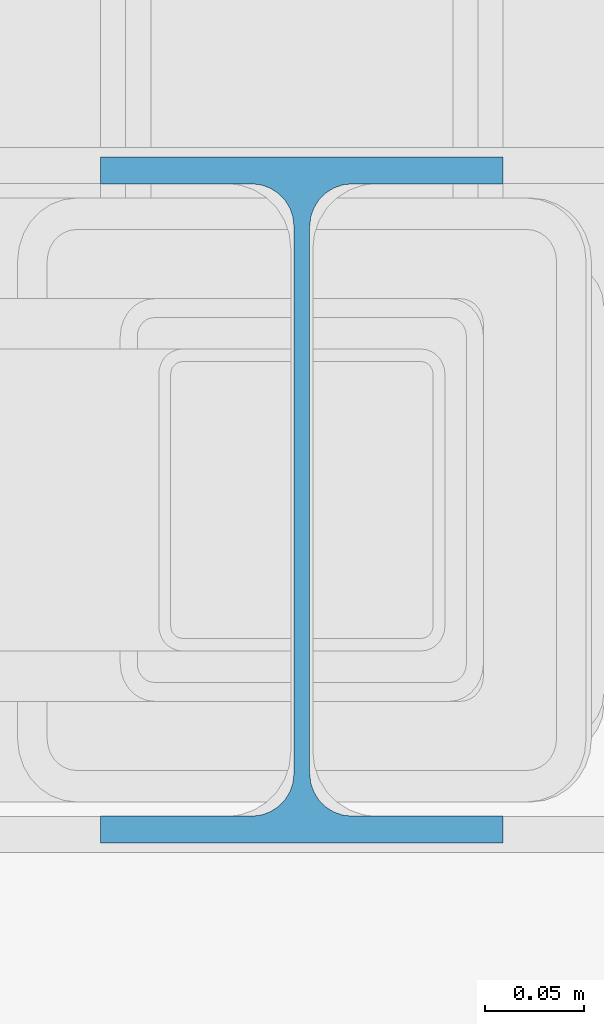
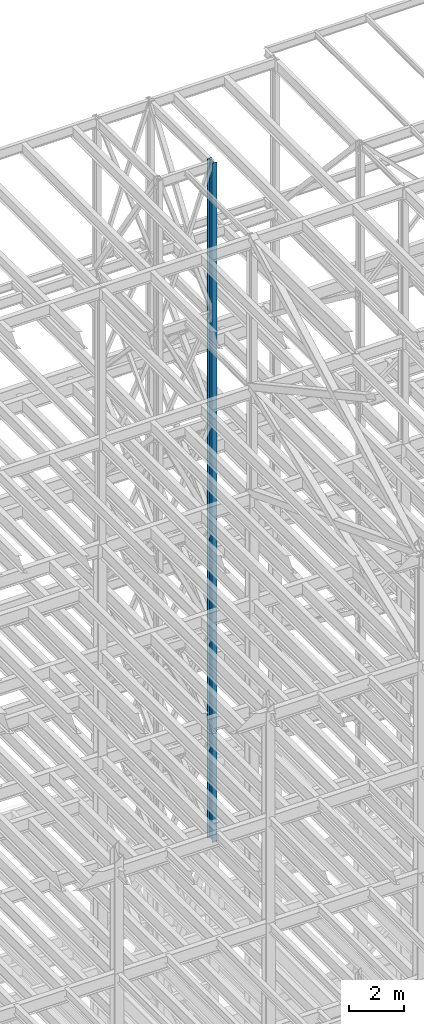
# One storey, part 104 of 150: 3 columns.
"""IFC2X3 building model written with IfcOpenShell, lengths in millimetres."""

from ifc_helpers import new_model, si_unit, frame, origin_with_axes, origin_2d_with_axis, place, context, subcontext, project, spatial, i_section, extrude, material, type_object, element, save


model = new_model("IFC2X3")

# Units and contexts
model_context = context("Model", 3, precision=1e-05, world=origin_with_axes())
body_context = subcontext(model_context, "Body", "Model", "MODEL_VIEW")
ifc_project = project(units=[si_unit("LENGTHUNIT", "METRE", prefix="MILLI"), si_unit("AREAUNIT", "SQUARE_METRE"), si_unit("VOLUMEUNIT", "CUBIC_METRE"), si_unit("MASSUNIT", "GRAM", prefix="KILO"), si_unit("TIMEUNIT", "SECOND"), si_unit("PLANEANGLEUNIT", "RADIAN"), si_unit("SOLIDANGLEUNIT", "STERADIAN"), si_unit("THERMODYNAMICTEMPERATUREUNIT", "DEGREE_CELSIUS"), si_unit("LUMINOUSINTENSITYUNIT", "LUMEN")], contexts=[model_context])

# Site, building, storey
site_placement = place(None, origin_with_axes())
site = spatial("IfcSite", under=ifc_project, at=site_placement, CompositionType="ELEMENT")
building_placement = place(site_placement, origin_with_axes())
building = spatial("IfcBuilding", under=site, at=building_placement, Name="Undefined", CompositionType="ELEMENT")
storey_placement = place(building_placement, origin_with_axes())
storey = spatial("IfcBuildingStorey", under=building, at=storey_placement, Name="Undefined", CompositionType="ELEMENT", Elevation=0.0)

# Columns
ifc_material = material(Name="STEEL/A992")
column_type = type_object("IfcColumnType", Name="W14X43", PredefinedType="NOTDEFINED")
column_placement = place(storey_placement, frame((76923.9, 27355.8, 54483.0), z_axis=(0.0, 0.0, 1.0), x_axis=(1.0, 0.0, 0.0)))
element("IfcColumn", 1, at=column_placement, inside=storey, type_object=column_type, material=ifc_material, Name="COLUMN", ObjectType="W14X43", context=body_context, shape_type="SweptSolid", body=[
    extrude(i_section(OverallWidth=203.2, OverallDepth=346.075, WebThickness=7.9375, FlangeThickness=13.462, FilletRadius=21.4629, at=origin_2d_with_axis()), frame((0.0, 0.0, 11429.998857), z_axis=(0.0, 0.0, -1.0), x_axis=(-1.0, 0.0, 0.0)), (0.0, 0.0, 1.0), 11429.998857),
])
for number, where, z_axis, x_axis, name in (
    (2, (76923.9, 27355.8, 45034.2), (0.0, 0.0, 1.0), (1.0, 0.0, 0.0), "COLUMN"),
    (3, (76923.9, 27355.8, 35585.4), (0.0, 0.0, 1.0), (1.0, 0.0, 0.0), "COLUMN"),
):
    element("IfcColumn", number, at=place(storey_placement, frame(where, z_axis=z_axis, x_axis=x_axis)), inside=storey, type_object=column_type, material=ifc_material, Name=name, ObjectType="W14X43", context=body_context, shape_type="SweptSolid", body=[
        extrude(i_section(OverallWidth=203.2, OverallDepth=346.075, WebThickness=7.9375, FlangeThickness=13.462, FilletRadius=21.4629, at=origin_2d_with_axis()), frame((0.0, 0.0, 9448.8), z_axis=(0.0, 0.0, -1.0), x_axis=(-1.0, 0.0, 0.0)), (0.0, 0.0, 1.0), 9448.8),
    ])

save(model, "model.ifc")
